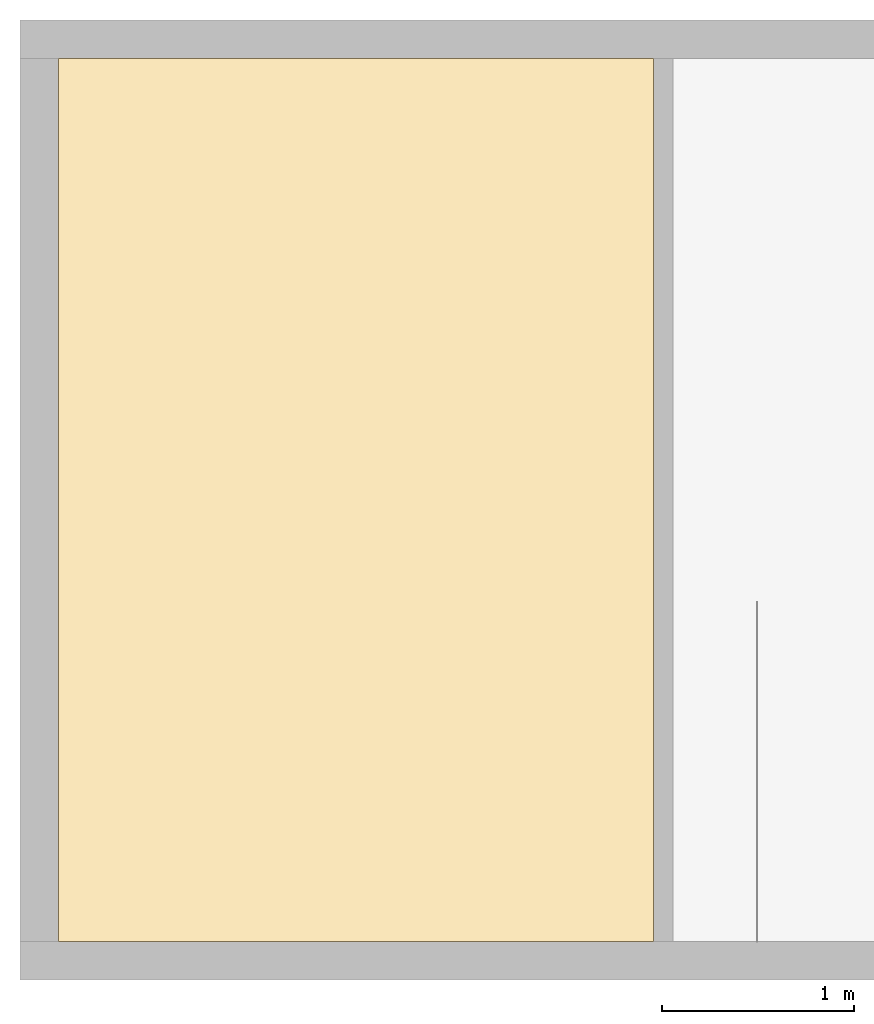
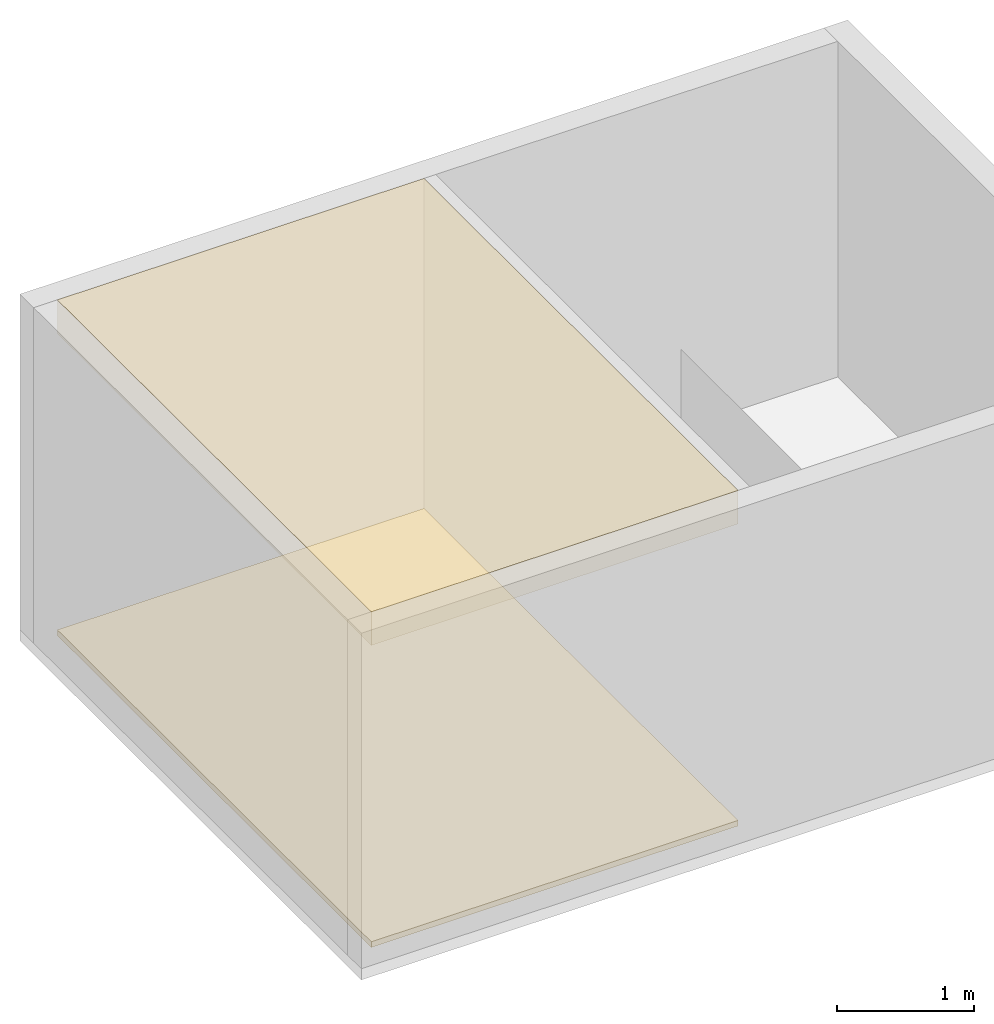
# One storey, part 2 of 3: 2 coverings.
"""IFC4 building model written with IfcOpenShell, lengths in metres."""

from ifc_helpers import new_model, entity, si_unit, converted_unit, frame, origin_with_axes, origin_2d_with_axis, place, context, subcontext, project, spatial, line, indexed_curve, outline, extrude, material, layer, layer_set, layer_usage, type_object, element, save


model = new_model("IFC4")

# Units and contexts
model_context = context("Model", 3, precision=1e-05, world=origin_with_axes())
plan_context = context("Plan", 2, precision=1e-05, world=origin_2d_with_axis())
body_context = subcontext(model_context, "Body", "Model", "MODEL_VIEW")
ifc_project = project(units=[si_unit("VOLUMEUNIT", "CUBIC_METRE"), si_unit("LENGTHUNIT", "METRE"), converted_unit("PLANEANGLEUNIT", "degree", entity("IfcReal", 0.0174532925199433), si_unit("PLANEANGLEUNIT", "RADIAN"), dimensions=[0, 0, 0, 0, 0, 0, 0]), si_unit("AREAUNIT", "SQUARE_METRE")], contexts=[model_context, plan_context])

# Site, building, storey, space
site_placement = place(None, origin_with_axes())
site = spatial("IfcSite", under=ifc_project, at=site_placement)
building_placement = place(site_placement, origin_with_axes())
building = spatial("IfcBuilding", under=site, at=building_placement, Name="Building")
storey_placement = place(building_placement, origin_with_axes())
storey = spatial("IfcBuildingStorey", under=building, at=storey_placement, Name="Storey")
space_placement = place(storey_placement, frame((1.90752410888672, 0.740174770355225, 0.0), z_axis=(0.0, 0.0, 1.0), x_axis=(1.0, 0.0, 0.0)))
space = spatial("IfcSpace", under=storey, at=space_placement)

# Coverings
ifc_material = material()
ifc_layer_1 = layer(ifc_material, 0.0500000007450581)
ifc_layer_set_1 = layer_set([ifc_layer_1])
ifc_layer_usage_1 = layer_usage(ifc_layer_set_1, "AXIS3", "POSITIVE", 0.0)
covering_type_1 = type_object("IfcCoveringType", Name="FLR-01", PredefinedType="FLOORING", material=ifc_layer_set_1)
covering_1_placement = place(space_placement, frame((-1.707524061203, -0.540174782276154, 0.0), z_axis=(0.0, 0.0, 1.0), x_axis=(1.0, 0.0, 0.0)))
element("IfcCovering", 1, at=covering_1_placement, inside=space, type_object=covering_type_1, material=ifc_layer_usage_1, Name="floor.001", PredefinedType="FLOORING", context=body_context, shape_type="SweptSolid", body=[
    extrude(outline(indexed_curve([(0.0, 0.0), (3.10065317153931, 0.0), (3.10065317153931, 4.60000038146973), (0.0, 4.60000038146973)], segments=[line(3, 2), line(2, 1), line(1, 4), line(4, 3)], self_intersect=False)), None, (0.0, 0.0, 1.0), 0.0500000007450581),
])
ifc_layer_2 = layer(ifc_material, 0.300000011920929)
ifc_layer_set_2 = layer_set([ifc_layer_2])
ifc_layer_usage_2 = layer_usage(ifc_layer_set_2, "AXIS3", "POSITIVE", 0.0)
covering_type_2 = type_object("IfcCoveringType", Name="CEL-01", PredefinedType="CEILING", material=ifc_layer_set_2)
covering_2_placement = place(space_placement, frame((-1.707524061203, -0.540174782276154, 2.70000004768372), z_axis=(0.0, 0.0, 1.0), x_axis=(1.0, 0.0, 0.0)))
element("IfcCovering", 2, at=covering_2_placement, inside=space, type_object=covering_type_2, material=ifc_layer_usage_2, Name="ceiling", PredefinedType="CEILING", context=body_context, shape_type="SweptSolid", body=[
    extrude(outline(indexed_curve([(3.10065078735352, 4.60000133514404), (3.10065078735352, 0.0), (0.0, 0.0), (0.0, 4.60000133514404)], segments=[line(4, 1), line(1, 2), line(2, 3), line(3, 4)], self_intersect=False)), None, (0.0, 0.0, 1.0), 0.300000011920929),
])

save(model, "model.ifc")
